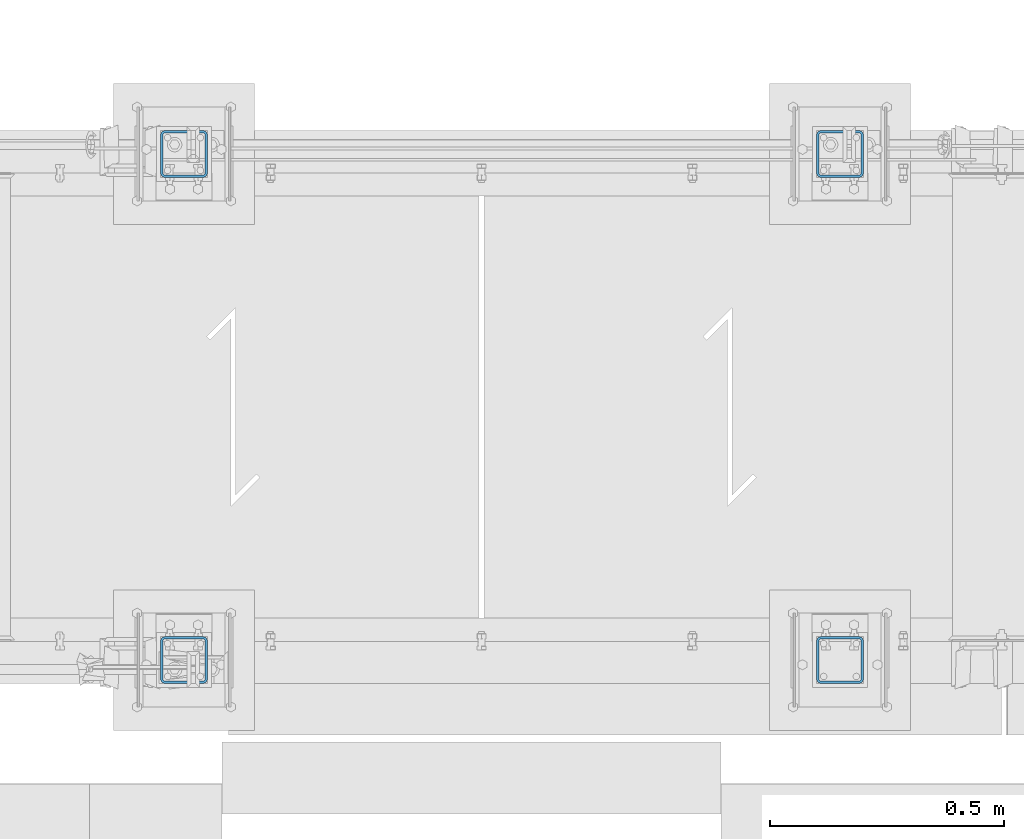
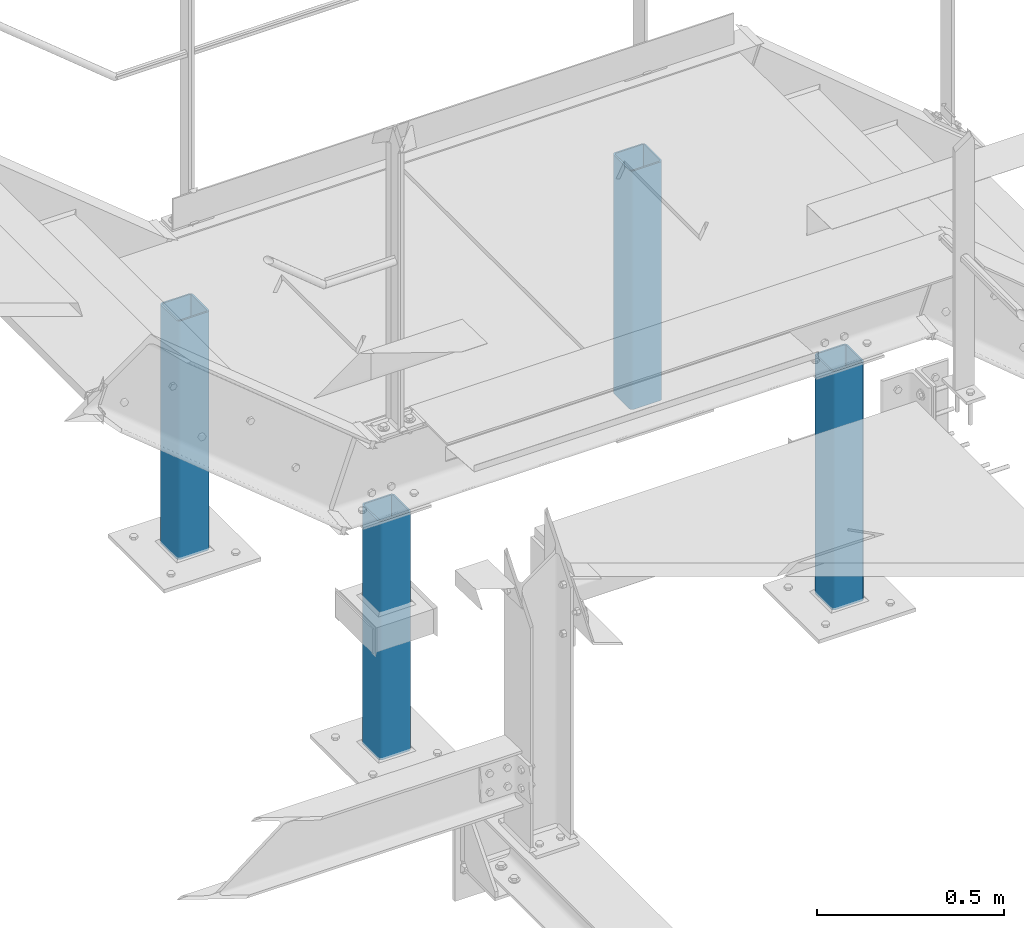
# One storey, part 35 of 496: 4 columns, 4 elements without a shape of their own.
"""IFC2X3 building model written with IfcOpenShell, lengths in millimetres."""

from ifc_helpers import new_model, si_unit, frame, origin_with_axes, origin_2d_with_axis, place, context, subcontext, project, spatial, hollow_rectangle, extrude, material, type_object, element, aggregate, save


model = new_model("IFC2X3")

# Units and contexts
model_context = context("Model", 3, precision=1e-05, world=origin_with_axes())
body_context = subcontext(model_context, "Body", "Model", "MODEL_VIEW")
ifc_project = project(units=[si_unit("LENGTHUNIT", "METRE", prefix="MILLI"), si_unit("AREAUNIT", "SQUARE_METRE"), si_unit("VOLUMEUNIT", "CUBIC_METRE"), si_unit("MASSUNIT", "GRAM", prefix="KILO"), si_unit("TIMEUNIT", "SECOND"), si_unit("PLANEANGLEUNIT", "RADIAN"), si_unit("SOLIDANGLEUNIT", "STERADIAN"), si_unit("THERMODYNAMICTEMPERATUREUNIT", "DEGREE_CELSIUS"), si_unit("LUMINOUSINTENSITYUNIT", "LUMEN")], contexts=[model_context])

# Site, building, storey
site_placement = place(None, origin_with_axes())
site = spatial("IfcSite", under=ifc_project, at=site_placement, CompositionType="ELEMENT")
building_placement = place(site_placement, origin_with_axes())
building = spatial("IfcBuilding", under=site, at=building_placement, Name="Undefined", CompositionType="ELEMENT")
storey_placement = place(building_placement, origin_with_axes())
storey = spatial("IfcBuildingStorey", under=building, at=storey_placement, Name="Undefined", CompositionType="ELEMENT", Elevation=0.0)

# Assembly, column
assembly_1_placement = place(storey_placement, origin_with_axes())
assembly_1 = element("IfcElementAssembly", 1, at=assembly_1_placement, inside=storey, AssemblyPlace="NOTDEFINED", PredefinedType="NOTDEFINED")
ifc_material = material(Name="Undefined/S235-E24")
column_type = type_object("IfcColumnType", PredefinedType="NOTDEFINED")
column_1_placement = place(assembly_1_placement, frame((23455.0, 15990.0001225752, 7062.0), z_axis=(0.0, 0.0, 1.0), x_axis=(0.0, 1.0, 0.0)))
column_1 = element("IfcColumn", 2, at=column_1_placement, type_object=column_type, material=ifc_material, context=body_context, shape_type="SweptSolid", body=[
    extrude(hollow_rectangle(XDim=100.0, YDim=100.0, WallThickness=5.0, InnerFilletRadius=5.0, OuterFilletRadius=10.0, at=origin_2d_with_axis()), frame((0.0, 0.0, 780.000011607546), z_axis=(0.0, 0.0, -1.0), x_axis=(0.0, 1.0, 0.0)), (0.0, 0.0, 1.0), 780.0),
])
aggregate(assembly_1, [column_1])

assembly_2_placement = place(storey_placement, origin_with_axes())
assembly_2 = element("IfcElementAssembly", 3, at=assembly_2_placement, inside=storey, AssemblyPlace="NOTDEFINED", PredefinedType="NOTDEFINED")
column_2_placement = place(assembly_2_placement, frame((24855.0, 15990.0001225752, 7062.0), z_axis=(0.0, 0.0, 1.0), x_axis=(0.0, 1.0, 0.0)))
column_2 = element("IfcColumn", 4, at=column_2_placement, type_object=column_type, material=ifc_material, context=body_context, shape_type="SweptSolid", body=[
    extrude(hollow_rectangle(XDim=100.0, YDim=100.0, WallThickness=5.0, InnerFilletRadius=5.0, OuterFilletRadius=10.0, at=origin_2d_with_axis()), frame((0.0, 0.0, 780.000011607546), z_axis=(0.0, 0.0, -1.0), x_axis=(0.0, 1.0, 0.0)), (0.0, 0.0, 1.0), 780.0),
])
aggregate(assembly_2, [column_2])

assembly_3_placement = place(storey_placement, origin_with_axes())
assembly_3 = element("IfcElementAssembly", 5, at=assembly_3_placement, inside=storey, AssemblyPlace="NOTDEFINED", PredefinedType="NOTDEFINED")
column_3_placement = place(assembly_3_placement, frame((23455.0, 17069.9998774248, 7062.0), z_axis=(0.0, 0.0, 1.0), x_axis=(0.0, -1.0, 0.0)))
column_3 = element("IfcColumn", 6, at=column_3_placement, type_object=column_type, material=ifc_material, context=body_context, shape_type="SweptSolid", body=[
    extrude(hollow_rectangle(XDim=100.0, YDim=100.0, WallThickness=5.0, InnerFilletRadius=5.0, OuterFilletRadius=10.0, at=origin_2d_with_axis()), frame((0.0, 0.0, 780.000011607546), z_axis=(0.0, 0.0, -1.0), x_axis=(0.0, 1.0, 0.0)), (0.0, 0.0, 1.0), 780.0),
])
aggregate(assembly_3, [column_3])

assembly_4_placement = place(storey_placement, origin_with_axes())
assembly_4 = element("IfcElementAssembly", 7, at=assembly_4_placement, inside=storey, AssemblyPlace="NOTDEFINED", PredefinedType="NOTDEFINED")
column_4_placement = place(assembly_4_placement, frame((24855.0, 17069.9998774248, 7062.0), z_axis=(0.0, 0.0, 1.0), x_axis=(0.0, -1.0, 0.0)))
column_4 = element("IfcColumn", 8, at=column_4_placement, type_object=column_type, material=ifc_material, context=body_context, shape_type="SweptSolid", body=[
    extrude(hollow_rectangle(XDim=100.0, YDim=100.0, WallThickness=5.0, InnerFilletRadius=5.0, OuterFilletRadius=10.0, at=origin_2d_with_axis()), frame((0.0, 0.0, 780.000011607546), z_axis=(0.0, 0.0, -1.0), x_axis=(0.0, 1.0, 0.0)), (0.0, 0.0, 1.0), 780.0),
])
aggregate(assembly_4, [column_4])

save(model, "model.ifc")
